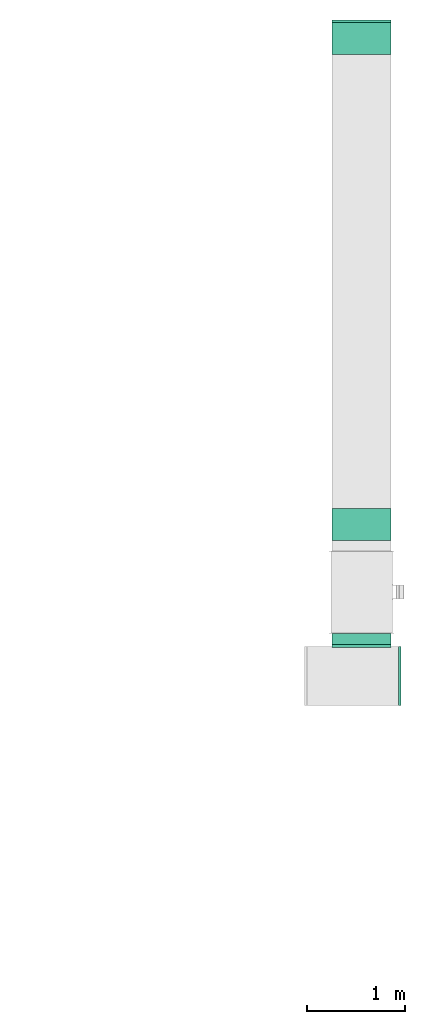
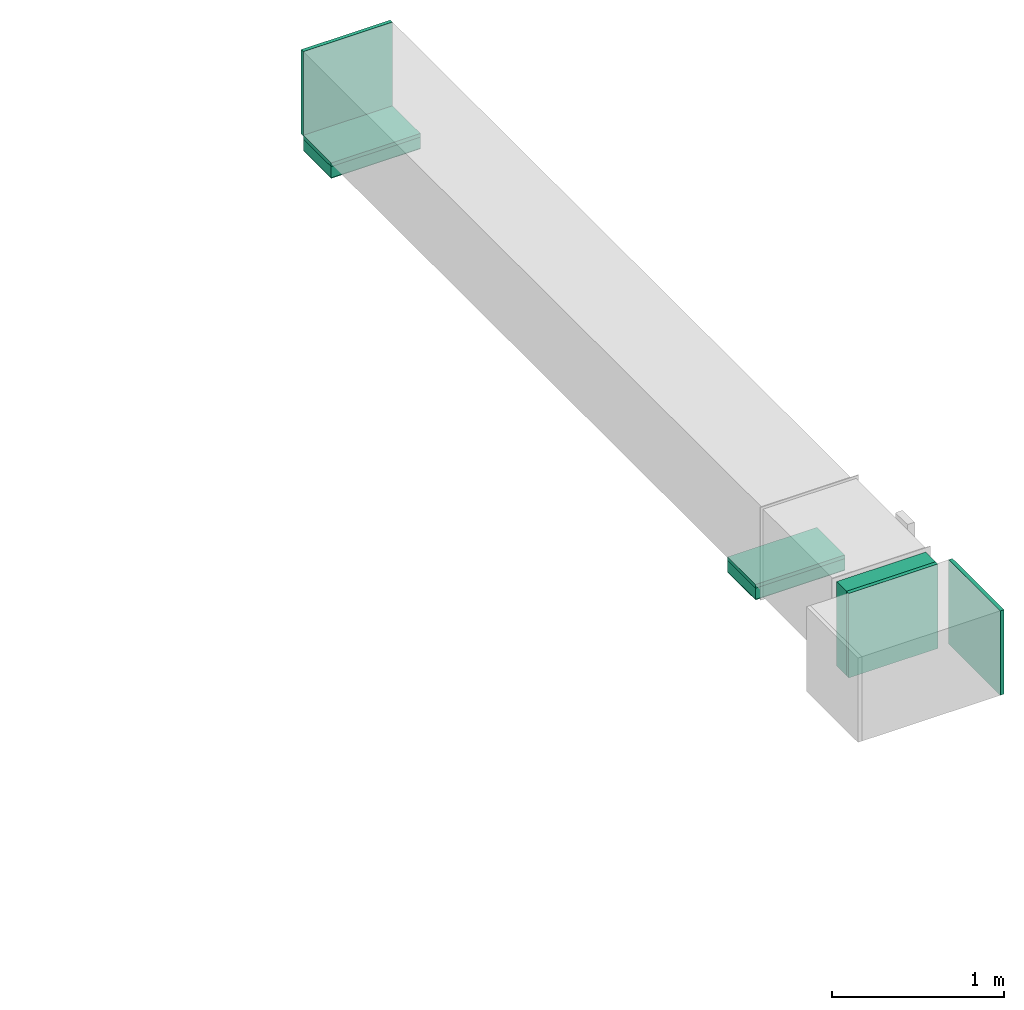
# One storey, part 5 of 9: 5 flow fittings, 3 flow segments, 2 flow terminals.
"""IFC2X3 building model written with IfcOpenShell, lengths in millimetres."""

from ifc_helpers import new_model, entity, si_unit, converted_unit, derived_unit, direction, frame, origin, origin_2d_with_axis, place, context, subcontext, project, spatial, rectangle, extrude, source, transform, mapped, material, type_object, type_shapes, element, save


model = new_model("IFC2X3")

# Units and contexts
model_context = context("Model", 3, precision=0.01, world=origin(), true_north=direction((6.12303176911189e-17, 1.0)))
body_context = subcontext(model_context, "Body", "Model", "MODEL_VIEW")
ifc_project = project(units=[si_unit("LENGTHUNIT", "METRE", prefix="MILLI"), si_unit("AREAUNIT", "SQUARE_METRE"), si_unit("VOLUMEUNIT", "CUBIC_METRE"), converted_unit("PLANEANGLEUNIT", "DEGREE", entity("IfcRatioMeasure", 0.0174532925199433), si_unit("PLANEANGLEUNIT", "RADIAN"), dimensions=[0, 0, 0, 0, 0, 0, 0]), si_unit("MASSUNIT", "GRAM", prefix="KILO"), derived_unit("MASSDENSITYUNIT", [(si_unit("MASSUNIT", "GRAM", prefix="KILO"), 1), (si_unit("LENGTHUNIT", "METRE"), -3)]), derived_unit("MOMENTOFINERTIAUNIT", [(si_unit("LENGTHUNIT", "METRE"), 4)]), si_unit("TIMEUNIT", "SECOND"), si_unit("FREQUENCYUNIT", "HERTZ"), si_unit("THERMODYNAMICTEMPERATUREUNIT", "DEGREE_CELSIUS"), derived_unit("THERMALTRANSMITTANCEUNIT", [(si_unit("MASSUNIT", "GRAM", prefix="KILO"), 1), (si_unit("THERMODYNAMICTEMPERATUREUNIT", "KELVIN"), -1), (si_unit("TIMEUNIT", "SECOND"), -3)]), derived_unit("VOLUMETRICFLOWRATEUNIT", [(si_unit("LENGTHUNIT", "METRE"), 3), (si_unit("TIMEUNIT", "SECOND"), -1)]), derived_unit("MASSFLOWRATEUNIT", [(si_unit("MASSUNIT", "GRAM", prefix="KILO"), 1), (si_unit("TIMEUNIT", "SECOND"), -1)]), derived_unit("ROTATIONALFREQUENCYUNIT", [(si_unit("TIMEUNIT", "SECOND"), -1)]), si_unit("ELECTRICCURRENTUNIT", "AMPERE"), si_unit("ELECTRICVOLTAGEUNIT", "VOLT"), si_unit("POWERUNIT", "WATT"), si_unit("FORCEUNIT", "NEWTON", prefix="KILO"), si_unit("ILLUMINANCEUNIT", "LUX"), si_unit("LUMINOUSFLUXUNIT", "LUMEN"), si_unit("LUMINOUSINTENSITYUNIT", "CANDELA"), derived_unit("USERDEFINED", [(si_unit("MASSUNIT", "GRAM", prefix="KILO"), -1), (si_unit("LENGTHUNIT", "METRE"), -2), (si_unit("TIMEUNIT", "SECOND"), 3), (si_unit("LUMINOUSFLUXUNIT", "LUMEN"), 1)]), derived_unit("LINEARVELOCITYUNIT", [(si_unit("LENGTHUNIT", "METRE"), 1), (si_unit("TIMEUNIT", "SECOND"), -1)]), si_unit("PRESSUREUNIT", "PASCAL"), derived_unit("USERDEFINED", [(si_unit("LENGTHUNIT", "METRE"), -2), (si_unit("MASSUNIT", "GRAM", prefix="KILO"), 1), (si_unit("TIMEUNIT", "SECOND"), -2)]), derived_unit("LINEARFORCEUNIT", [(si_unit("MASSUNIT", "GRAM", prefix="KILO"), 1), (si_unit("LENGTHUNIT", "METRE"), 1), (si_unit("TIMEUNIT", "SECOND"), -2), (si_unit("LENGTHUNIT", "METRE"), -1)]), derived_unit("PLANARFORCEUNIT", [(si_unit("MASSUNIT", "GRAM", prefix="KILO"), 1), (si_unit("LENGTHUNIT", "METRE"), 1), (si_unit("TIMEUNIT", "SECOND"), -2), (si_unit("LENGTHUNIT", "METRE"), -2)])], contexts=[model_context])

# Site, building, storey
site_placement = place(None, origin())
site = spatial("IfcSite", under=ifc_project, at=site_placement, CompositionType="ELEMENT")
building_placement = place(site_placement, origin())
building = spatial("IfcBuilding", under=site, at=building_placement, CompositionType="ELEMENT")
storey_placement = place(building_placement, frame((0.0, 0.0, 24000.0)))
storey = spatial("IfcBuildingStorey", under=building, at=storey_placement, CompositionType="ELEMENT", Elevation=24000.0)

# Flow segments
duct_segment_type = type_object("IfcDuctSegmentType", PredefinedType="NOTDEFINED")
flow_segment_1_placement = place(storey_placement, frame((63544.88, 12186.68, 2400.0)))
element("IfcFlowSegment", 1, at=flow_segment_1_placement, inside=storey, type_object=duct_segment_type, context=body_context, shape_type="SweptSolid", body=[
    extrude(rectangle(XDim=600.000000000002, YDim=325.0, at=origin_2d_with_axis()), frame((300.0, 162.5, 0.0), z_axis=(0.0, 0.0, 1.0), x_axis=(-1.0, 0.0, 0.0)), (0.0, 0.0, 1.0), 79.5999999999992),
])
flow_segment_2_placement = place(storey_placement, frame((63544.88, 17126.33, 2400.0)))
element("IfcFlowSegment", 2, at=flow_segment_2_placement, inside=storey, type_object=duct_segment_type, context=body_context, shape_type="SweptSolid", body=[
    extrude(rectangle(XDim=600.000000000002, YDim=325.0, at=origin_2d_with_axis()), frame((300.0, 162.5, 0.0), z_axis=(0.0, 0.0, 1.0), x_axis=(-1.0, 0.0, 0.0)), (0.0, 0.0, 1.0), 79.6000000002634),
])
flow_segment_3_placement = place(storey_placement, frame((63544.88, 11128.5, 2499.6)))
element("IfcFlowSegment", 3, at=flow_segment_3_placement, inside=storey, type_object=duct_segment_type, context=body_context, shape_type="SweptSolid", body=[
    extrude(rectangle(XDim=114.291507549948, YDim=600.000000000002, at=origin_2d_with_axis()), frame((300.0, 57.15, 0.0), z_axis=(0.0, 0.0, 1.0), x_axis=(0.0, 1.0, 0.0)), (0.0, 0.0, 1.0), 600.000000000002),
])

# Flow fittings
ifc_material_1 = material()
duct_fitting_type_1 = type_object("IfcDuctFittingType", PredefinedType="NOTDEFINED", material=ifc_material_1)
shared_shape_1 = source(origin(), body_context, "Body", "SweptSolid", [
    extrude(rectangle(XDim=600.0, YDim=26.0960000000043, at=origin_2d_with_axis()), frame((6.95, 0.0, -300.0), z_axis=(0.0, 0.0, 1.0), x_axis=(0.0, -1.0, 0.0)), (0.0, 0.0, 1.0), 600.0),
])
type_shapes(duct_fitting_type_1, [shared_shape_1])
flow_fitting_1_placement = place(storey_placement, frame((63844.88, 11108.5, 2799.6), z_axis=(0.0, 0.0, -1.0), x_axis=(0.0, 1.0, 0.0)))
element("IfcFlowFitting", 4, at=flow_fitting_1_placement, inside=storey, type_object=duct_fitting_type_1, material=ifc_material_1, context=body_context, shape_type="MappedRepresentation", body=[
    mapped(shared_shape_1, transform((0.0, 0.0, 0.0), scale=1.0)),
])
duct_fitting_type_2 = type_object("IfcDuctFittingType", PredefinedType="NOTDEFINED", material=ifc_material_1)
shared_shape_2 = source(origin(), body_context, "Body", "SweptSolid", [
    extrude(rectangle(XDim=26.0960000000009, YDim=600.0, at=origin_2d_with_axis()), frame((6.95, 0.0, -162.5)), (0.0, 0.0, 1.0), 325.0),
])
type_shapes(duct_fitting_type_2, [shared_shape_2])
flow_fitting_2_placement = place(storey_placement, frame((63844.88, 12349.18, 2499.6), z_axis=(0.0, 1.0, 0.0), x_axis=(0.0, 0.0, -1.0)))
element("IfcFlowFitting", 5, at=flow_fitting_2_placement, inside=storey, type_object=duct_fitting_type_2, material=ifc_material_1, context=body_context, shape_type="MappedRepresentation", body=[
    mapped(shared_shape_2, transform((0.0, 0.0, 0.0), scale=1.0)),
])
duct_fitting_type_3 = type_object("IfcDuctFittingType", PredefinedType="NOTDEFINED", material=ifc_material_1)
shared_shape_3 = source(origin(), body_context, "Body", "SweptSolid", [
    extrude(rectangle(XDim=24.9999999999999, YDim=600.0, at=origin_2d_with_axis()), frame((12.5, 0.0, -300.0)), (0.0, 0.0, 1.0), 600.0),
])
type_shapes(duct_fitting_type_3, [shared_shape_3])
flow_fitting_3_placement = place(storey_placement, frame((63844.88, 17451.33, 2799.6), z_axis=(0.0, 0.0, 1.0), x_axis=(0.0, 1.0, 0.0)))
element("IfcFlowFitting", 6, at=flow_fitting_3_placement, inside=storey, type_object=duct_fitting_type_3, material=ifc_material_1, context=body_context, shape_type="MappedRepresentation", body=[
    mapped(shared_shape_3, transform((0.0, 0.0, 0.0), scale=1.0)),
])
flow_fitting_4_placement = place(storey_placement, frame((64220.83, 10808.5, 2799.6)))
element("IfcFlowFitting", 7, at=flow_fitting_4_placement, inside=storey, type_object=duct_fitting_type_3, material=ifc_material_1, context=body_context, shape_type="MappedRepresentation", body=[
    mapped(shared_shape_3, transform((0.0, 0.0, 0.0), scale=1.0)),
])
duct_fitting_type_4 = type_object("IfcDuctFittingType", PredefinedType="NOTDEFINED", material=ifc_material_1)
shared_shape_4 = source(origin(), body_context, "Body", "SweptSolid", [
    extrude(rectangle(XDim=600.0, YDim=26.096, at=origin_2d_with_axis()), frame((6.95, 0.0, -162.5), z_axis=(0.0, 0.0, 1.0), x_axis=(0.0, -1.0, 0.0)), (0.0, 0.0, 1.0), 325.0),
])
type_shapes(duct_fitting_type_4, [shared_shape_4])
flow_fitting_5_placement = place(storey_placement, frame((63844.88, 17288.83, 2499.6), z_axis=(0.0, -1.0, 0.0), x_axis=(0.0, 0.0, -1.0)))
element("IfcFlowFitting", 8, at=flow_fitting_5_placement, inside=storey, type_object=duct_fitting_type_4, material=ifc_material_1, context=body_context, shape_type="MappedRepresentation", body=[
    mapped(shared_shape_4, transform((0.0, 0.0, 0.0), scale=1.0)),
])

# Flow terminals
ifc_material_2 = material()
air_terminal_type = type_object("IfcAirTerminalType", PredefinedType="NOTDEFINED", material=ifc_material_2)
shared_shape_5 = source(origin(), body_context, "Body", "SweptSolid", [
    extrude(rectangle(XDim=4.0, YDim=599.999999999999, at=origin_2d_with_axis()), frame((0.0, -2.0, -162.5), z_axis=(0.0, 0.0, 1.0), x_axis=(0.0, 1.0, 0.0)), (0.0, 0.0, 1.0), 325.000000000005),
])
type_shapes(air_terminal_type, [shared_shape_5])
for number, where, z_axis, x_axis in (
    (9, (63844.88, 17288.83, 2400.0), (0.0, -1.0, 0.0), (1.0, 0.0, 0.0)),
    (10, (63844.88, 12349.18, 2400.0), (0.0, -1.0, 0.0), (1.0, 0.0, 0.0)),
):
    element("IfcFlowTerminal", number, at=place(storey_placement, frame(where, z_axis=z_axis, x_axis=x_axis)), inside=storey, type_object=air_terminal_type, material=ifc_material_2, context=body_context, shape_type="MappedRepresentation", body=[
        mapped(shared_shape_5, transform((0.0, 0.0, 0.0), scale=1.0)),
    ])

save(model, "model.ifc")
